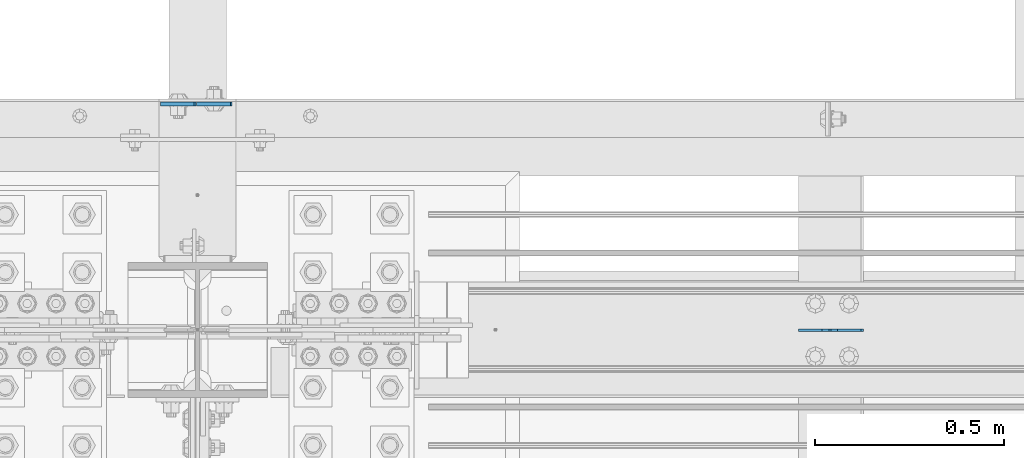
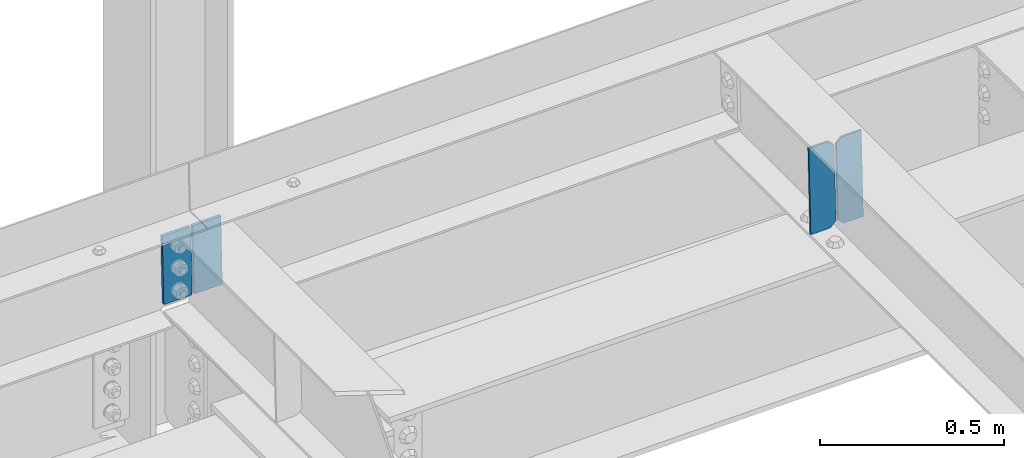
# One storey, part 3479 of 3843: 4 plates, 2 elements without a shape of their own.
"""IFC2X3 building model written with IfcOpenShell, lengths in millimetres."""

import ifcopenshell
import ifcopenshell.guid

model = None  # the IFC model being written
_history = None  # IfcOwnerHistory: only IFC2X3 demands one
_inside = {}  # id of a spatial element -> (the spatial element, [elements in it])
_under = {}  # id of a project, library or spatial element -> (it, [spatial elements below it])
_declared = {}  # id of a project -> (the project, [libraries it declares])
_typed = {}  # id of a type object -> (the type object, [elements of that type])
_made_of = {}  # id of a material, layer set ... -> (it, [elements and type objects made of it])


def new_model(schema):
    """Start an empty IFC model of exactly this schema.

    Asked for "IFC4X3", IfcOpenShell would pick the latest addendum, in which some entities
    have other attributes; the version numbers below select the first issue.
    IFC2X3 requires an IfcOwnerHistory on every rooted entity: one is made here for all.
    """
    global model, _history
    if schema == "IFC4X3":
        model = ifcopenshell.file(schema_version=(4, 3, 0, 0))
    else:
        model = ifcopenshell.file(schema=schema)
    _inside.clear()
    _under.clear()
    _declared.clear()
    _typed.clear()
    _made_of.clear()
    _history = None
    if model.schema == "IFC2X3":
        org = make("IfcOrganization", Name="unknown")
        user = make(
            "IfcPersonAndOrganization",
            ThePerson=make("IfcPerson", FamilyName="unknown"),
            TheOrganization=org,
        )
        app = make(
            "IfcApplication",
            ApplicationDeveloper=org,
            Version="unknown",
            ApplicationFullName="unknown",
            ApplicationIdentifier="unknown",
        )
        _history = make(
            "IfcOwnerHistory",
            OwningUser=user,
            OwningApplication=app,
            ChangeAction="ADDED",
            CreationDate=0,
        )
    return model


def make(cls, **values):
    """One entity of the class cls with the attributes given. An attribute that is None is left unset."""
    return model.create_entity(
        cls, **{name: value for name, value in values.items() if value is not None}
    )


def rooted(cls, **values):
    """An entity with a GlobalId (a new one), such as an element, a storey or a relation."""
    return make(cls, GlobalId=ifcopenshell.guid.new(), OwnerHistory=_history, **values)


def si_unit(unit_type, name, prefix=None):
    """IfcSIUnit, for example si_unit("LENGTHUNIT", "METRE", prefix="MILLI")."""
    return make("IfcSIUnit", UnitType=unit_type, Prefix=prefix, Name=name)


def assignment(units):
    """IfcUnitAssignment: the units of a project."""
    return None if units is None else make("IfcUnitAssignment", Units=units)


def point(xyz):
    """IfcCartesianPoint."""
    return None if xyz is None else make("IfcCartesianPoint", Coordinates=xyz)


def direction(xyz):
    """IfcDirection."""
    return None if xyz is None else make("IfcDirection", DirectionRatios=xyz)


def frame(location, z_axis=None, x_axis=None):
    """IfcAxis2Placement3D, a coordinate frame: its origin and axes. An axis left out is left unset."""
    return make(
        "IfcAxis2Placement3D",
        Location=point(location),
        Axis=direction(z_axis),
        RefDirection=direction(x_axis),
    )


def origin_with_axes():
    """The frame at (0, 0, 0) with the z axis (0, 0, 1) and the x axis (1, 0, 0) written out."""
    return frame((0.0, 0.0, 0.0), z_axis=(0.0, 0.0, 1.0), x_axis=(1.0, 0.0, 0.0))


def place(relative_to, where):
    """IfcLocalPlacement: puts the frame where relative to a parent placement (None: the world)."""
    return make(
        "IfcLocalPlacement", PlacementRelTo=relative_to, RelativePlacement=where
    )


def context(
    kind, dimensions, precision=None, world=None, true_north=None, identifier=None
):
    """IfcGeometricRepresentationContext, for example the 3D "Model" context."""
    return make(
        "IfcGeometricRepresentationContext",
        ContextIdentifier=identifier,
        ContextType=kind,
        CoordinateSpaceDimension=dimensions,
        Precision=precision,
        WorldCoordinateSystem=world,
        TrueNorth=true_north,
    )


def subcontext(parent, identifier, kind, view, scale=None):
    """IfcGeometricRepresentationSubContext, for example "Body" below "Model"."""
    return make(
        "IfcGeometricRepresentationSubContext",
        ContextIdentifier=identifier,
        ContextType=kind,
        ParentContext=parent,
        TargetScale=scale,
        TargetView=view,
    )


def project(units=None, contexts=None):
    """IfcProject with its units and contexts."""
    return rooted(
        "IfcProject",
        Name="project",
        RepresentationContexts=contexts,
        UnitsInContext=assignment(units),
    )


def spatial(cls, under=None, at=None, **own):
    """A site, building, storey or space (cls), placed at a placement, below another one or the project."""
    s = rooted(cls, ObjectPlacement=at, **own)
    if under is not None:
        _under.setdefault(under.id(), (under, []))[1].append(s)
    return s


def faces_of(points, faces, orient=None, outer=None):
    """IfcFace entities. A face is a list of loops; a loop is a list of indices into points, from 0.

    orient and outer hold one flag for each loop. By default every Orientation is true, the
    first loop of a face is its IfcFaceOuterBound and the others are IfcFaceBound.
    """
    made = []
    for i, loops in enumerate(faces):
        bounds = []
        for j, loop in enumerate(loops):
            is_outer = j == 0 if outer is None else outer[i][j]
            bounds.append(
                make(
                    "IfcFaceOuterBound" if is_outer else "IfcFaceBound",
                    Bound=make("IfcPolyLoop", Polygon=[points[k] for k in loop]),
                    Orientation=True if orient is None else orient[i][j],
                )
            )
        made.append(make("IfcFace", Bounds=bounds))
    return made


def faceted_brep(points, faces, orient=None, outer=None, voids=None):
    """IfcFacetedBrep: a solid bounded by flat faces; with voids (closed shells), ...WithVoids."""
    shared = [point(p) for p in points]
    hull = make("IfcClosedShell", CfsFaces=faces_of(shared, faces, orient, outer))
    if voids is None:
        return make("IfcFacetedBrep", Outer=hull)
    return make(
        "IfcFacetedBrepWithVoids",
        Outer=hull,
        Voids=[
            make(cls, CfsFaces=faces_of(shared, fs, o, b)) for cls, fs, o, b in voids
        ],
    )


def shape(context_of_items, identifier, shape_type, items):
    """IfcShapeRepresentation: the items that make up one representation, for example the "Body"."""
    return make(
        "IfcShapeRepresentation",
        ContextOfItems=context_of_items,
        RepresentationIdentifier=identifier,
        RepresentationType=shape_type,
        Items=items,
    )


def material(Name=None, Category=None):
    """IfcMaterial."""
    return make("IfcMaterial", Name=Name, Category=Category)


def made_of(thing, what):
    """Note that an element or type object is made of a material, layer set ...; save() writes the relation."""
    if what is not None:
        _made_of.setdefault(what.id(), (what, []))[1].append(thing)
    return thing


def type_object(cls, material=None, **own):
    """A type object (cls), such as IfcWallType, which elements share."""
    return made_of(rooted(cls, **own), material)


def element(
    cls,
    number,
    at=None,
    inside=None,
    cuts=None,
    type_object=None,
    material=None,
    context=None,
    identifier="Body",
    shape_type=None,
    held_by="IfcProductDefinitionShape",
    body=None,
    shapes=None,
    **own,
):
    """One element of the class cls, such as IfcWall. Its Tag is "e" and its number.

    at: its placement. inside: the storey or other place that contains it. cuts: it is an
    opening in that element (IfcRelVoidsElement). A single representation is given by context,
    identifier, shape_type and body (its items); several are given by shapes. held_by: the class
    of the entity that holds the representations. save() writes the other relations.
    """
    e = rooted(cls, Tag="e%d" % number, ObjectPlacement=at, **own)
    if body is not None:
        shapes = [shape(context, identifier, shape_type, body)]
    if shapes is not None:
        e.Representation = make(held_by, Representations=shapes)
    if inside is not None:
        _inside.setdefault(inside.id(), (inside, []))[1].append(e)
    if cuts is not None:
        rooted(
            "IfcRelVoidsElement", RelatingBuildingElement=cuts, RelatedOpeningElement=e
        )
    if type_object is not None:
        _typed.setdefault(type_object.id(), (type_object, []))[1].append(e)
    return made_of(e, material)


def aggregate(whole, parts):
    """IfcRelAggregates: a whole, such as a stair, and the parts it consists of."""
    return rooted("IfcRelAggregates", RelatingObject=whole, RelatedObjects=parts)


def save(model, path):
    """Write the relations noted so far, then the file.

    IfcRelAggregates (storeys below a building ...), IfcRelContainedInSpatialStructure (elements
    in a storey), IfcRelDefinesByType, IfcRelAssociatesMaterial and IfcRelDeclares: one each for
    every whole, place, type object, material and project.
    """
    for whole, parts in _under.values():
        aggregate(whole, parts)
    for where, things in _inside.values():
        rooted(
            "IfcRelContainedInSpatialStructure",
            RelatedElements=things,
            RelatingStructure=where,
        )
    for kind, things in _typed.values():
        rooted("IfcRelDefinesByType", RelatedObjects=things, RelatingType=kind)
    for what, things in _made_of.values():
        rooted("IfcRelAssociatesMaterial", RelatedObjects=things, RelatingMaterial=what)
    for by, libraries in _declared.values():
        rooted("IfcRelDeclares", RelatingContext=by, RelatedDefinitions=libraries)
    model.write(path)


model = new_model("IFC2X3")

# Units and contexts
model_context = context("Model", 3, precision=1e-05, world=origin_with_axes())
body_context = subcontext(model_context, "Body", "Model", "MODEL_VIEW")
ifc_project = project(units=[si_unit("LENGTHUNIT", "METRE", prefix="MILLI"), si_unit("AREAUNIT", "SQUARE_METRE"), si_unit("VOLUMEUNIT", "CUBIC_METRE"), si_unit("MASSUNIT", "GRAM", prefix="KILO"), si_unit("TIMEUNIT", "SECOND"), si_unit("PLANEANGLEUNIT", "RADIAN"), si_unit("SOLIDANGLEUNIT", "STERADIAN"), si_unit("THERMODYNAMICTEMPERATUREUNIT", "DEGREE_CELSIUS"), si_unit("LUMINOUSINTENSITYUNIT", "LUMEN")], contexts=[model_context])

# Site, building, storey
site_placement = place(None, origin_with_axes())
site = spatial("IfcSite", under=ifc_project, at=site_placement, CompositionType="ELEMENT")
building_placement = place(site_placement, origin_with_axes())
building = spatial("IfcBuilding", under=site, at=building_placement, Name="Undefined", CompositionType="ELEMENT")
storey_placement = place(building_placement, origin_with_axes())
storey = spatial("IfcBuildingStorey", under=building, at=storey_placement, Name="Undefined", CompositionType="ELEMENT", Elevation=0.0)

# Assembly, plates
assembly_1_placement = place(storey_placement, origin_with_axes())
assembly_1 = element("IfcElementAssembly", 1, at=assembly_1_placement, inside=storey, Name="BEAM", AssemblyPlace="NOTDEFINED", PredefinedType="RIGID_FRAME")
ifc_material = material(Name="STEEL/A572-50")
plate_type_1 = type_object("IfcPlateType", PredefinedType="NOTDEFINED")
plate_1_placement = place(assembly_1_placement, frame((55928.1991027339, 92811.5999983762, 46100.917317835), z_axis=(0.999776270257024, 0.0, 0.0211520550054619), x_axis=(0.0211520550054438, 0.0, -0.999776270257025)))
plate_1 = element("IfcPlate", 2, at=plate_1_placement, type_object=plate_type_1, material=ifc_material, Name="PLATE", context=body_context, shape_type="Brep", body=[
    faceted_brep([(0.0, -4.76249999999709, 0.0), (0.0, -4.76249999999709, 88.9000015258789), (0.0, 4.76249999999709, 88.9000015258789), (0.0, 4.76249999999709, 0.0), (228.600006102781, -4.7625000004191, 88.9000015257589), (228.600006102781, 4.76249999954598, 88.9000015257443), (228.600006103079, -4.7625000004482, 7.27595761418343e-12), (228.600006103079, 4.76249999954598, -7.27595761418343e-12)], [[[0, 1, 2, 3]], [[1, 4, 5, 2]], [[4, 6, 7, 5]], [[6, 0, 3, 7]], [[5, 7, 3, 2]], [[6, 4, 1, 0]]]),
])
plate_2_placement = place(assembly_1_placement, frame((55921.8503106385, 92811.5999988976, 46100.7829965945), z_axis=(-0.999776270257024, 0.0, -0.0211520550054595), x_axis=(0.0211520550054438, 0.0, -0.999776270257025)))
plate_2 = element("IfcPlate", 3, at=plate_2_placement, type_object=plate_type_1, material=ifc_material, Name="PLATE", context=body_context, shape_type="Brep", body=[
    faceted_brep([(0.0, -4.76249999999709, 0.0), (0.0, -4.76249999999709, 88.9000015258789), (0.0, 4.76249999999709, 88.9000015258789), (0.0, 4.76249999999709, 0.0), (228.600006102781, -4.7625000004191, 88.9000015257589), (228.600006102781, 4.76249999954598, 88.9000015257443), (228.600006103079, -4.7625000004482, 7.27595761418343e-12), (228.600006103079, 4.76249999954598, -7.27595761418343e-12)], [[[0, 1, 2, 3]], [[1, 4, 5, 2]], [[4, 6, 7, 5]], [[6, 0, 3, 7]], [[5, 7, 3, 2]], [[6, 4, 1, 0]]]),
])
aggregate(assembly_1, [plate_1, plate_2])

assembly_2_placement = place(storey_placement, origin_with_axes())
assembly_2 = element("IfcElementAssembly", 4, at=assembly_2_placement, inside=storey, Name="BEAM", AssemblyPlace="NOTDEFINED", PredefinedType="RIGID_FRAME")
plate_type_2 = type_object("IfcPlateType", PredefinedType="NOTDEFINED")
plate_3_placement = place(assembly_2_placement, frame((57689.4964783878, 92214.1769702767, 45876.8850897887), z_axis=(-0.0211520979448979, 0.00114771399952588, 0.999775610577246), x_axis=(-0.999776269348562, -2.42820000429985e-05, -0.0211520840073776)))
plate_3 = element("IfcPlate", 5, at=plate_3_placement, type_object=plate_type_2, material=ifc_material, Name="STIFFENER", context=body_context, shape_type="Brep", body=[
    faceted_brep([(0.0, -3.17499999999927, 0.0), (6.83940015733242e-10, -3.17499999996653, 288.924999998613), (6.54836185276508e-10, 3.17500000001746, 288.924999998591), (0.0, 3.17499999999927, 0.0), (61.9125003828667, -3.17499999997744, 288.924999998599), (61.9125003828522, 3.17500000002838, 288.924999998584), (79.3750000013097, -3.17499999997744, 271.462500380039), (79.375000001266, 3.17500000002838, 271.462500380017), (79.375000000713, -3.17499999999927, 17.4624996185448), (79.3750000006694, 3.17500000000291, 17.462499618523), (61.9125003821828, -3.17499999999563, -1.45519152283669e-11), (61.9125003821682, 3.17500000000655, -2.91038304567337e-11)], [[[0, 1, 2, 3]], [[1, 4, 5, 2]], [[4, 6, 7, 5]], [[6, 8, 9, 7]], [[8, 10, 11, 9]], [[10, 0, 3, 11]], [[5, 7, 9, 11, 3, 2]], [[10, 8, 6, 4, 1, 0]]]),
])
plate_4_placement = place(assembly_2_placement, frame((57603.7906576981, 92214.1748887026, 45875.0718273835), z_axis=(-0.0211520979448979, 0.00114771399952588, 0.999775610577246), x_axis=(-0.999776269348562, -2.42820000429985e-05, -0.0211520840073776)))
plate_4 = element("IfcPlate", 6, at=plate_4_placement, type_object=plate_type_2, material=ifc_material, Name="STIFFENER", context=body_context, shape_type="Brep", body=[
    faceted_brep([(5.82076609134674e-11, -3.17499999999927, 17.4624996185667), (6.25732354819775e-10, -3.17499999997744, 271.462500380054), (5.82076609134674e-10, 3.17500000002474, 271.462500380039), (0.0, 3.17500000000655, 17.4624996185521), (17.462499619156, -3.17499999997744, 288.924999998606), (17.4624996191269, 3.17500000002474, 288.924999998591), (79.3750000013242, -3.17500000025029, 288.924999998591), (79.3750000013097, 3.1749999997337, 288.92499999857), (79.3750000006548, -3.17500000026484, -2.18278728425503e-11), (79.3750000006403, 3.17499999969732, -2.91038304567337e-11), (17.4624996184866, -3.17500000000291, 7.27595761418343e-12), (17.462499618443, 3.17500000000291, -7.27595761418343e-12)], [[[0, 1, 2, 3]], [[1, 4, 5, 2]], [[4, 6, 7, 5]], [[6, 8, 9, 7]], [[8, 10, 11, 9]], [[10, 0, 3, 11]], [[5, 7, 9, 11, 3, 2]], [[10, 8, 6, 4, 1, 0]]]),
])
aggregate(assembly_2, [plate_3, plate_4])

save(model, "model.ifc")
